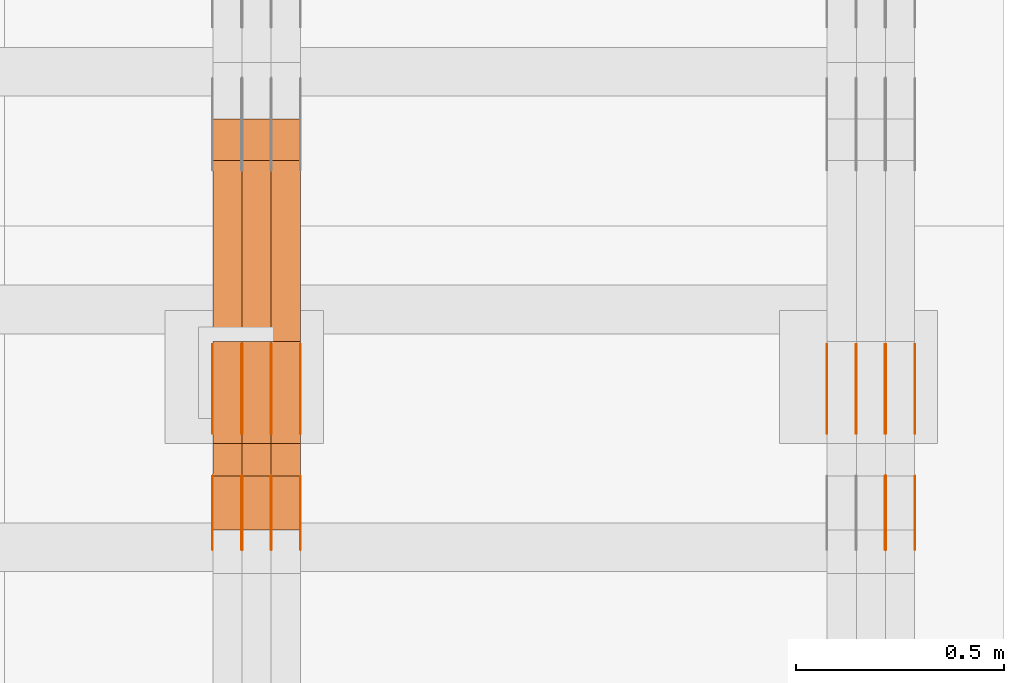
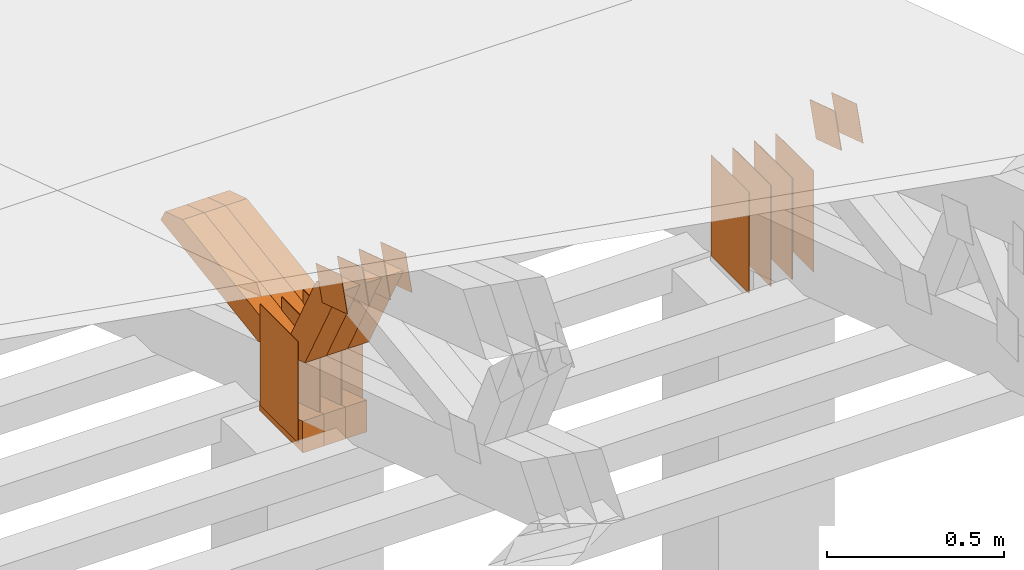
# One storey, part 327 of 385: 30 proxies.
"""IFC2X3 building model written with IfcOpenShell, lengths in millimetres."""

from ifc_helpers import new_model, entity, si_unit, converted_unit, derived_unit, direction, frame, origin, origin_2d_with_axis, place, context, subcontext, project, spatial, polyline, rectangle, outline, extrude, source, transform, mapped, material, type_object, type_shapes, element, save


model = new_model("IFC2X3")

# Units and contexts
model_context = context("Model", 3, precision=0.01, world=origin(), true_north=direction((6.12303176911189e-17, 1.0)))
body_context = subcontext(model_context, "Body", "Model", "MODEL_VIEW")
ifc_project = project(units=[si_unit("LENGTHUNIT", "METRE", prefix="MILLI"), si_unit("AREAUNIT", "SQUARE_METRE"), si_unit("VOLUMEUNIT", "CUBIC_METRE"), converted_unit("PLANEANGLEUNIT", "DEGREE", entity("IfcRatioMeasure", 0.0174532925199433), si_unit("PLANEANGLEUNIT", "RADIAN"), dimensions=[0, 0, 0, 0, 0, 0, 0]), si_unit("MASSUNIT", "GRAM", prefix="KILO"), derived_unit("MASSDENSITYUNIT", [(si_unit("MASSUNIT", "GRAM", prefix="KILO"), 1), (si_unit("LENGTHUNIT", "METRE"), -3)]), si_unit("TIMEUNIT", "SECOND"), si_unit("FREQUENCYUNIT", "HERTZ"), si_unit("THERMODYNAMICTEMPERATUREUNIT", "DEGREE_CELSIUS"), derived_unit("THERMALTRANSMITTANCEUNIT", [(si_unit("MASSUNIT", "GRAM", prefix="KILO"), 1), (si_unit("THERMODYNAMICTEMPERATUREUNIT", "KELVIN"), -1), (si_unit("TIMEUNIT", "SECOND"), -3)]), derived_unit("VOLUMETRICFLOWRATEUNIT", [(si_unit("LENGTHUNIT", "METRE"), 3), (si_unit("TIMEUNIT", "SECOND"), -1)]), si_unit("ELECTRICCURRENTUNIT", "AMPERE"), si_unit("ELECTRICVOLTAGEUNIT", "VOLT"), si_unit("POWERUNIT", "WATT"), si_unit("FORCEUNIT", "NEWTON", prefix="KILO"), si_unit("ILLUMINANCEUNIT", "LUX"), si_unit("LUMINOUSFLUXUNIT", "LUMEN"), si_unit("LUMINOUSINTENSITYUNIT", "CANDELA"), derived_unit("USERDEFINED", [(si_unit("MASSUNIT", "GRAM", prefix="KILO"), -1), (si_unit("LENGTHUNIT", "METRE"), -2), (si_unit("TIMEUNIT", "SECOND"), 3), (si_unit("LUMINOUSFLUXUNIT", "LUMEN"), 1)]), derived_unit("LINEARVELOCITYUNIT", [(si_unit("LENGTHUNIT", "METRE"), 1), (si_unit("TIMEUNIT", "SECOND"), -1)]), si_unit("PRESSUREUNIT", "PASCAL"), derived_unit("USERDEFINED", [(si_unit("LENGTHUNIT", "METRE"), -2), (si_unit("MASSUNIT", "GRAM", prefix="KILO"), 1), (si_unit("TIMEUNIT", "SECOND"), -2)])], contexts=[model_context])

# Site, building, storey
site_placement = place(None, origin())
site = spatial("IfcSite", under=ifc_project, at=site_placement, CompositionType="ELEMENT")
building_placement = place(site_placement, origin())
building = spatial("IfcBuilding", under=site, at=building_placement, CompositionType="ELEMENT")
storey_placement = place(building_placement, origin())
storey = spatial("IfcBuildingStorey", under=building, at=storey_placement, Name="Default", CompositionType="ELEMENT", Elevation=0.0)

# Proxies
ifc_material_1 = material(Name="IfcSurfaceStyle #615826")
building_element_proxy_type_1 = type_object("IfcBuildingElementProxyType", PredefinedType="NOTDEFINED", material=ifc_material_1)
shared_shape_1 = source(origin(), body_context, "Body", "SweptSolid", [
    extrude(rectangle(XDim=350.0, YDim=215.999999999984, at=origin_2d_with_axis()), frame((175.0, 108.0, 0.0), z_axis=(0.0, 0.0, 1.0), x_axis=(-1.0, 0.0, 0.0)), (0.0, 0.0, 1.0), 1.29999999999999),
])
type_shapes(building_element_proxy_type_1, [shared_shape_1])
proxy_1_placement = place(building_placement, frame((49861.3, 17459.2939453125, 3165.36425781251), z_axis=(-1.0, 0.0, 0.0), x_axis=(0.0, 0.0, -1.0)))
element("IfcBuildingElementProxy", 1, at=proxy_1_placement, inside=storey, type_object=building_element_proxy_type_1, material=ifc_material_1, context=body_context, shape_type="MappedRepresentation", body=[
    mapped(shared_shape_1, transform((0.0, 0.0, 0.0), scale=1.0)),
])
ifc_material_2 = material(Name="IfcSurfaceStyle #615769")
building_element_proxy_type_2 = type_object("IfcBuildingElementProxyType", PredefinedType="NOTDEFINED", material=ifc_material_2)
shared_shape_2 = source(origin(), body_context, "Body", "SweptSolid", [
    extrude(rectangle(XDim=350.0, YDim=215.999999999984, at=origin_2d_with_axis()), frame((175.0, 108.0, 0.0), z_axis=(0.0, 0.0, 1.0), x_axis=(-1.0, 0.0, 0.0)), (0.0, 0.0, 1.0), 1.29999999999999),
])
type_shapes(building_element_proxy_type_2, [shared_shape_2])
proxy_2_placement = place(building_placement, frame((49790.0, 17459.2939453125, 3165.36425781251), z_axis=(-1.0, 0.0, 0.0), x_axis=(0.0, 0.0, -1.0)))
element("IfcBuildingElementProxy", 2, at=proxy_2_placement, inside=storey, type_object=building_element_proxy_type_2, material=ifc_material_2, context=body_context, shape_type="MappedRepresentation", body=[
    mapped(shared_shape_2, transform((0.0, 0.0, 0.0), scale=1.0)),
])
ifc_material_3 = material(Name="IfcSurfaceStyle #615712")
building_element_proxy_type_3 = type_object("IfcBuildingElementProxyType", PredefinedType="NOTDEFINED", material=ifc_material_3)
shared_shape_3 = source(origin(), body_context, "Body", "SweptSolid", [
    extrude(rectangle(XDim=350.0, YDim=215.999999999984, at=origin_2d_with_axis()), frame((175.0, 108.0, 0.0), z_axis=(0.0, 0.0, 1.0), x_axis=(-1.0, 0.0, 0.0)), (0.0, 0.0, 1.0), 1.29999999999999),
])
type_shapes(building_element_proxy_type_3, [shared_shape_3])
proxy_3_placement = place(building_placement, frame((49791.3, 17459.2939453125, 3165.36425781251), z_axis=(-1.0, 0.0, 0.0), x_axis=(0.0, 0.0, -1.0)))
element("IfcBuildingElementProxy", 3, at=proxy_3_placement, inside=storey, type_object=building_element_proxy_type_3, material=ifc_material_3, context=body_context, shape_type="MappedRepresentation", body=[
    mapped(shared_shape_3, transform((0.0, 0.0, 0.0), scale=1.0)),
])
ifc_material_4 = material(Name="IfcSurfaceStyle #615655")
building_element_proxy_type_4 = type_object("IfcBuildingElementProxyType", PredefinedType="NOTDEFINED", material=ifc_material_4)
shared_shape_4 = source(origin(), body_context, "Body", "SweptSolid", [
    extrude(rectangle(XDim=350.0, YDim=215.999999999984, at=origin_2d_with_axis()), frame((175.0, 108.0, 0.0), z_axis=(0.0, 0.0, 1.0), x_axis=(-1.0, 0.0, 0.0)), (0.0, 0.0, 1.0), 1.29999999999998),
])
type_shapes(building_element_proxy_type_4, [shared_shape_4])
proxy_4_placement = place(building_placement, frame((49720.0, 17459.2939453125, 3165.36425781251), z_axis=(-1.0, 0.0, 0.0), x_axis=(0.0, 0.0, -1.0)))
element("IfcBuildingElementProxy", 4, at=proxy_4_placement, inside=storey, type_object=building_element_proxy_type_4, material=ifc_material_4, context=body_context, shape_type="MappedRepresentation", body=[
    mapped(shared_shape_4, transform((0.0, 0.0, 0.0), scale=1.0)),
])
ifc_material_5 = material(Name="IfcSurfaceStyle #615598")
building_element_proxy_type_5 = type_object("IfcBuildingElementProxyType", PredefinedType="NOTDEFINED", material=ifc_material_5)
shared_shape_5 = source(origin(), body_context, "Body", "SweptSolid", [
    extrude(rectangle(XDim=350.0, YDim=215.999999999984, at=origin_2d_with_axis()), frame((175.0, 108.0, 0.0), z_axis=(0.0, 0.0, 1.0), x_axis=(-1.0, 0.0, 0.0)), (0.0, 0.0, 1.0), 1.29999999999998),
])
type_shapes(building_element_proxy_type_5, [shared_shape_5])
proxy_5_placement = place(building_placement, frame((49721.3, 17459.2939453125, 3165.36425781251), z_axis=(-1.0, 0.0, 0.0), x_axis=(0.0, 0.0, -1.0)))
element("IfcBuildingElementProxy", 5, at=proxy_5_placement, inside=storey, type_object=building_element_proxy_type_5, material=ifc_material_5, context=body_context, shape_type="MappedRepresentation", body=[
    mapped(shared_shape_5, transform((0.0, 0.0, 0.0), scale=1.0)),
])
ifc_material_6 = material(Name="IfcSurfaceStyle #615541")
building_element_proxy_type_6 = type_object("IfcBuildingElementProxyType", PredefinedType="NOTDEFINED", material=ifc_material_6)
shared_shape_6 = source(origin(), body_context, "Body", "SweptSolid", [
    extrude(rectangle(XDim=350.0, YDim=215.999999999984, at=origin_2d_with_axis()), frame((175.0, 108.0, 0.0), z_axis=(0.0, 0.0, 1.0), x_axis=(-1.0, 0.0, 0.0)), (0.0, 0.0, 1.0), 1.29999999999998),
])
type_shapes(building_element_proxy_type_6, [shared_shape_6])
proxy_6_placement = place(building_placement, frame((49650.0, 17459.2939453125, 3165.36425781251), z_axis=(-1.0, 0.0, 0.0), x_axis=(0.0, 0.0, -1.0)))
element("IfcBuildingElementProxy", 6, at=proxy_6_placement, inside=storey, type_object=building_element_proxy_type_6, material=ifc_material_6, context=body_context, shape_type="MappedRepresentation", body=[
    mapped(shared_shape_6, transform((0.0, 0.0, 0.0), scale=1.0)),
])
ifc_material_7 = material(Name="IfcSurfaceStyle #612406")
building_element_proxy_type_7 = type_object("IfcBuildingElementProxyType", PredefinedType="NOTDEFINED", material=ifc_material_7)
shared_shape_7 = source(origin(), body_context, "Body", "SweptSolid", [
    extrude(outline(polyline([(-74.9998605591058, -59.9999264677524), (74.999875428623, -59.9999264677524), (74.9998605591068, 59.9999264677524), (-74.9998754286239, 59.9999264677524), (-74.9998605591058, -59.9999264677524)])), frame((75.0002460484325, 60.0000016373508, 0.0), z_axis=(0.0, 0.0, 1.0), x_axis=(-1.0, 0.0, 0.0)), (0.0, 0.0, 1.0), 1.3),
])
type_shapes(building_element_proxy_type_7, [shared_shape_7])
proxy_7_placement = place(building_placement, frame((49861.3, 17107.0599369346, 3383.82825001787), z_axis=(-1.0, 0.0, 0.0), x_axis=(0.0, -0.951056516295154, 0.309016994374948)))
element("IfcBuildingElementProxy", 7, at=proxy_7_placement, inside=storey, type_object=building_element_proxy_type_7, material=ifc_material_7, context=body_context, shape_type="MappedRepresentation", body=[
    mapped(shared_shape_7, transform((0.0, 0.0, 0.0), scale=1.0)),
])
ifc_material_8 = material(Name="IfcSurfaceStyle #612349")
building_element_proxy_type_8 = type_object("IfcBuildingElementProxyType", PredefinedType="NOTDEFINED", material=ifc_material_8)
shared_shape_8 = source(origin(), body_context, "Body", "SweptSolid", [
    extrude(outline(polyline([(-74.9998605591058, -59.9999264677524), (74.999875428623, -59.9999264677524), (74.9998605591068, 59.9999264677524), (-74.9998754286239, 59.9999264677524), (-74.9998605591058, -59.9999264677524)])), frame((75.0002460484325, 60.0000016373508, 0.0), z_axis=(0.0, 0.0, 1.0), x_axis=(-1.0, 0.0, 0.0)), (0.0, 0.0, 1.0), 1.3),
])
type_shapes(building_element_proxy_type_8, [shared_shape_8])
proxy_8_placement = place(building_placement, frame((49790.0, 17107.0599369346, 3383.82825001787), z_axis=(-1.0, 0.0, 0.0), x_axis=(0.0, -0.951056516295154, 0.309016994374948)))
element("IfcBuildingElementProxy", 8, at=proxy_8_placement, inside=storey, type_object=building_element_proxy_type_8, material=ifc_material_8, context=body_context, shape_type="MappedRepresentation", body=[
    mapped(shared_shape_8, transform((0.0, 0.0, 0.0), scale=1.0)),
])
ifc_material_9 = material(Name="IfcSurfaceStyle #612292")
building_element_proxy_type_9 = type_object("IfcBuildingElementProxyType", PredefinedType="NOTDEFINED", material=ifc_material_9)
shared_shape_9 = source(origin(), body_context, "Body", "SweptSolid", [
    extrude(outline(polyline([(-74.9998605591058, -59.9999264677524), (74.999875428623, -59.9999264677524), (74.9998605591068, 59.9999264677524), (-74.9998754286239, 59.9999264677524), (-74.9998605591058, -59.9999264677524)])), frame((75.0002460484325, 60.0000016373508, 0.0), z_axis=(0.0, 0.0, 1.0), x_axis=(-1.0, 0.0, 0.0)), (0.0, 0.0, 1.0), 1.3),
])
type_shapes(building_element_proxy_type_9, [shared_shape_9])
proxy_9_placement = place(building_placement, frame((49791.3, 17107.0599369346, 3383.82825001787), z_axis=(-1.0, 0.0, 0.0), x_axis=(0.0, -0.951056516295154, 0.309016994374948)))
element("IfcBuildingElementProxy", 9, at=proxy_9_placement, inside=storey, type_object=building_element_proxy_type_9, material=ifc_material_9, context=body_context, shape_type="MappedRepresentation", body=[
    mapped(shared_shape_9, transform((0.0, 0.0, 0.0), scale=1.0)),
])
ifc_material_10 = material(Name="IfcSurfaceStyle #581394")
building_element_proxy_type_10 = type_object("IfcBuildingElementProxyType", PredefinedType="NOTDEFINED", material=ifc_material_10)
shared_shape_10 = source(origin(), body_context, "Body", "SweptSolid", [
    extrude(rectangle(XDim=350.0, YDim=215.999999999984, at=origin_2d_with_axis()), frame((175.0, 108.0, 0.0), z_axis=(0.0, 0.0, 1.0), x_axis=(-1.0, 0.0, 0.0)), (0.0, 0.0, 1.0), 1.29999999999999),
])
type_shapes(building_element_proxy_type_10, [shared_shape_10])
proxy_10_placement = place(building_placement, frame((48386.3, 17459.2939453125, 3165.36425781251), z_axis=(-1.0, 0.0, 0.0), x_axis=(0.0, 0.0, -1.0)))
element("IfcBuildingElementProxy", 10, at=proxy_10_placement, inside=storey, type_object=building_element_proxy_type_10, material=ifc_material_10, context=body_context, shape_type="MappedRepresentation", body=[
    mapped(shared_shape_10, transform((0.0, 0.0, 0.0), scale=1.0)),
])
ifc_material_11 = material(Name="IfcSurfaceStyle #581337")
building_element_proxy_type_11 = type_object("IfcBuildingElementProxyType", PredefinedType="NOTDEFINED", material=ifc_material_11)
shared_shape_11 = source(origin(), body_context, "Body", "SweptSolid", [
    extrude(rectangle(XDim=350.0, YDim=215.999999999984, at=origin_2d_with_axis()), frame((175.0, 108.0, 0.0), z_axis=(0.0, 0.0, 1.0), x_axis=(-1.0, 0.0, 0.0)), (0.0, 0.0, 1.0), 1.29999999999999),
])
type_shapes(building_element_proxy_type_11, [shared_shape_11])
proxy_11_placement = place(building_placement, frame((48315.0, 17459.2939453125, 3165.36425781251), z_axis=(-1.0, 0.0, 0.0), x_axis=(0.0, 0.0, -1.0)))
element("IfcBuildingElementProxy", 11, at=proxy_11_placement, inside=storey, type_object=building_element_proxy_type_11, material=ifc_material_11, context=body_context, shape_type="MappedRepresentation", body=[
    mapped(shared_shape_11, transform((0.0, 0.0, 0.0), scale=1.0)),
])
ifc_material_12 = material(Name="IfcSurfaceStyle #581280")
building_element_proxy_type_12 = type_object("IfcBuildingElementProxyType", PredefinedType="NOTDEFINED", material=ifc_material_12)
shared_shape_12 = source(origin(), body_context, "Body", "SweptSolid", [
    extrude(rectangle(XDim=350.0, YDim=215.999999999984, at=origin_2d_with_axis()), frame((175.0, 108.0, 0.0), z_axis=(0.0, 0.0, 1.0), x_axis=(-1.0, 0.0, 0.0)), (0.0, 0.0, 1.0), 1.29999999999999),
])
type_shapes(building_element_proxy_type_12, [shared_shape_12])
proxy_12_placement = place(building_placement, frame((48316.3, 17459.2939453125, 3165.36425781251), z_axis=(-1.0, 0.0, 0.0), x_axis=(0.0, 0.0, -1.0)))
element("IfcBuildingElementProxy", 12, at=proxy_12_placement, inside=storey, type_object=building_element_proxy_type_12, material=ifc_material_12, context=body_context, shape_type="MappedRepresentation", body=[
    mapped(shared_shape_12, transform((0.0, 0.0, 0.0), scale=1.0)),
])
ifc_material_13 = material(Name="IfcSurfaceStyle #581223")
building_element_proxy_type_13 = type_object("IfcBuildingElementProxyType", PredefinedType="NOTDEFINED", material=ifc_material_13)
shared_shape_13 = source(origin(), body_context, "Body", "SweptSolid", [
    extrude(rectangle(XDim=350.0, YDim=215.999999999984, at=origin_2d_with_axis()), frame((175.0, 108.0, 0.0), z_axis=(0.0, 0.0, 1.0), x_axis=(-1.0, 0.0, 0.0)), (0.0, 0.0, 1.0), 1.29999999999998),
])
type_shapes(building_element_proxy_type_13, [shared_shape_13])
proxy_13_placement = place(building_placement, frame((48245.0, 17459.2939453125, 3165.36425781251), z_axis=(-1.0, 0.0, 0.0), x_axis=(0.0, 0.0, -1.0)))
element("IfcBuildingElementProxy", 13, at=proxy_13_placement, inside=storey, type_object=building_element_proxy_type_13, material=ifc_material_13, context=body_context, shape_type="MappedRepresentation", body=[
    mapped(shared_shape_13, transform((0.0, 0.0, 0.0), scale=1.0)),
])
ifc_material_14 = material(Name="IfcSurfaceStyle #581166")
building_element_proxy_type_14 = type_object("IfcBuildingElementProxyType", PredefinedType="NOTDEFINED", material=ifc_material_14)
shared_shape_14 = source(origin(), body_context, "Body", "SweptSolid", [
    extrude(rectangle(XDim=350.0, YDim=215.999999999984, at=origin_2d_with_axis()), frame((175.0, 108.0, 0.0), z_axis=(0.0, 0.0, 1.0), x_axis=(-1.0, 0.0, 0.0)), (0.0, 0.0, 1.0), 1.29999999999998),
])
type_shapes(building_element_proxy_type_14, [shared_shape_14])
proxy_14_placement = place(building_placement, frame((48246.3, 17459.2939453125, 3165.36425781251), z_axis=(-1.0, 0.0, 0.0), x_axis=(0.0, 0.0, -1.0)))
element("IfcBuildingElementProxy", 14, at=proxy_14_placement, inside=storey, type_object=building_element_proxy_type_14, material=ifc_material_14, context=body_context, shape_type="MappedRepresentation", body=[
    mapped(shared_shape_14, transform((0.0, 0.0, 0.0), scale=1.0)),
])
ifc_material_15 = material(Name="IfcSurfaceStyle #581109")
building_element_proxy_type_15 = type_object("IfcBuildingElementProxyType", PredefinedType="NOTDEFINED", material=ifc_material_15)
shared_shape_15 = source(origin(), body_context, "Body", "SweptSolid", [
    extrude(rectangle(XDim=350.0, YDim=215.999999999984, at=origin_2d_with_axis()), frame((175.0, 108.0, 0.0), z_axis=(0.0, 0.0, 1.0), x_axis=(-1.0, 0.0, 0.0)), (0.0, 0.0, 1.0), 1.29999999999998),
])
type_shapes(building_element_proxy_type_15, [shared_shape_15])
proxy_15_placement = place(building_placement, frame((48175.0, 17459.2939453125, 3165.36425781251), z_axis=(-1.0, 0.0, 0.0), x_axis=(0.0, 0.0, -1.0)))
element("IfcBuildingElementProxy", 15, at=proxy_15_placement, inside=storey, type_object=building_element_proxy_type_15, material=ifc_material_15, context=body_context, shape_type="MappedRepresentation", body=[
    mapped(shared_shape_15, transform((0.0, 0.0, 0.0), scale=1.0)),
])
ifc_material_16 = material(Name="IfcSurfaceStyle #577974")
building_element_proxy_type_16 = type_object("IfcBuildingElementProxyType", PredefinedType="NOTDEFINED", material=ifc_material_16)
shared_shape_16 = source(origin(), body_context, "Body", "SweptSolid", [
    extrude(outline(polyline([(-74.9998605591058, -59.9999264677524), (74.999875428623, -59.9999264677524), (74.9998605591068, 59.9999264677524), (-74.9998754286239, 59.9999264677524), (-74.9998605591058, -59.9999264677524)])), frame((75.0002460484325, 60.0000016373508, 0.0), z_axis=(0.0, 0.0, 1.0), x_axis=(-1.0, 0.0, 0.0)), (0.0, 0.0, 1.0), 1.3),
])
type_shapes(building_element_proxy_type_16, [shared_shape_16])
proxy_16_placement = place(building_placement, frame((48386.3, 17107.0599369346, 3383.82825001787), z_axis=(-1.0, 0.0, 0.0), x_axis=(0.0, -0.951056516295154, 0.309016994374948)))
element("IfcBuildingElementProxy", 16, at=proxy_16_placement, inside=storey, type_object=building_element_proxy_type_16, material=ifc_material_16, context=body_context, shape_type="MappedRepresentation", body=[
    mapped(shared_shape_16, transform((0.0, 0.0, 0.0), scale=1.0)),
])
ifc_material_17 = material(Name="IfcSurfaceStyle #577917")
building_element_proxy_type_17 = type_object("IfcBuildingElementProxyType", PredefinedType="NOTDEFINED", material=ifc_material_17)
shared_shape_17 = source(origin(), body_context, "Body", "SweptSolid", [
    extrude(outline(polyline([(-74.9998605591058, -59.9999264677524), (74.999875428623, -59.9999264677524), (74.9998605591068, 59.9999264677524), (-74.9998754286239, 59.9999264677524), (-74.9998605591058, -59.9999264677524)])), frame((75.0002460484325, 60.0000016373508, 0.0), z_axis=(0.0, 0.0, 1.0), x_axis=(-1.0, 0.0, 0.0)), (0.0, 0.0, 1.0), 1.3),
])
type_shapes(building_element_proxy_type_17, [shared_shape_17])
proxy_17_placement = place(building_placement, frame((48315.0, 17107.0599369346, 3383.82825001787), z_axis=(-1.0, 0.0, 0.0), x_axis=(0.0, -0.951056516295154, 0.309016994374948)))
element("IfcBuildingElementProxy", 17, at=proxy_17_placement, inside=storey, type_object=building_element_proxy_type_17, material=ifc_material_17, context=body_context, shape_type="MappedRepresentation", body=[
    mapped(shared_shape_17, transform((0.0, 0.0, 0.0), scale=1.0)),
])
ifc_material_18 = material(Name="IfcSurfaceStyle #577860")
building_element_proxy_type_18 = type_object("IfcBuildingElementProxyType", PredefinedType="NOTDEFINED", material=ifc_material_18)
shared_shape_18 = source(origin(), body_context, "Body", "SweptSolid", [
    extrude(outline(polyline([(-74.9998605591058, -59.9999264677524), (74.999875428623, -59.9999264677524), (74.9998605591068, 59.9999264677524), (-74.9998754286239, 59.9999264677524), (-74.9998605591058, -59.9999264677524)])), frame((75.0002460484325, 60.0000016373508, 0.0), z_axis=(0.0, 0.0, 1.0), x_axis=(-1.0, 0.0, 0.0)), (0.0, 0.0, 1.0), 1.3),
])
type_shapes(building_element_proxy_type_18, [shared_shape_18])
proxy_18_placement = place(building_placement, frame((48316.3, 17107.0599369346, 3383.82825001787), z_axis=(-1.0, 0.0, 0.0), x_axis=(0.0, -0.951056516295154, 0.309016994374948)))
element("IfcBuildingElementProxy", 18, at=proxy_18_placement, inside=storey, type_object=building_element_proxy_type_18, material=ifc_material_18, context=body_context, shape_type="MappedRepresentation", body=[
    mapped(shared_shape_18, transform((0.0, 0.0, 0.0), scale=1.0)),
])
ifc_material_19 = material(Name="IfcSurfaceStyle #577803")
building_element_proxy_type_19 = type_object("IfcBuildingElementProxyType", PredefinedType="NOTDEFINED", material=ifc_material_19)
shared_shape_19 = source(origin(), body_context, "Body", "SweptSolid", [
    extrude(outline(polyline([(-74.9998605591058, -59.9999264677524), (74.999875428623, -59.9999264677524), (74.9998605591068, 59.9999264677524), (-74.9998754286239, 59.9999264677524), (-74.9998605591058, -59.9999264677524)])), frame((75.0002460484325, 60.0000016373508, 0.0), z_axis=(0.0, 0.0, 1.0), x_axis=(-1.0, 0.0, 0.0)), (0.0, 0.0, 1.0), 1.29999999999999),
])
type_shapes(building_element_proxy_type_19, [shared_shape_19])
proxy_19_placement = place(building_placement, frame((48245.0, 17107.0599369346, 3383.82825001787), z_axis=(-1.0, 0.0, 0.0), x_axis=(0.0, -0.951056516295154, 0.309016994374948)))
element("IfcBuildingElementProxy", 19, at=proxy_19_placement, inside=storey, type_object=building_element_proxy_type_19, material=ifc_material_19, context=body_context, shape_type="MappedRepresentation", body=[
    mapped(shared_shape_19, transform((0.0, 0.0, 0.0), scale=1.0)),
])
ifc_material_20 = material(Name="IfcSurfaceStyle #577746")
building_element_proxy_type_20 = type_object("IfcBuildingElementProxyType", PredefinedType="NOTDEFINED", material=ifc_material_20)
shared_shape_20 = source(origin(), body_context, "Body", "SweptSolid", [
    extrude(outline(polyline([(-74.9998605591058, -59.9999264677524), (74.999875428623, -59.9999264677524), (74.9998605591068, 59.9999264677524), (-74.9998754286239, 59.9999264677524), (-74.9998605591058, -59.9999264677524)])), frame((75.0002460484325, 60.0000016373508, 0.0), z_axis=(0.0, 0.0, 1.0), x_axis=(-1.0, 0.0, 0.0)), (0.0, 0.0, 1.0), 1.29999999999999),
])
type_shapes(building_element_proxy_type_20, [shared_shape_20])
proxy_20_placement = place(building_placement, frame((48246.3, 17107.0599369346, 3383.82825001787), z_axis=(-1.0, 0.0, 0.0), x_axis=(0.0, -0.951056516295154, 0.309016994374948)))
element("IfcBuildingElementProxy", 20, at=proxy_20_placement, inside=storey, type_object=building_element_proxy_type_20, material=ifc_material_20, context=body_context, shape_type="MappedRepresentation", body=[
    mapped(shared_shape_20, transform((0.0, 0.0, 0.0), scale=1.0)),
])
ifc_material_21 = material(Name="IfcSurfaceStyle #577689")
building_element_proxy_type_21 = type_object("IfcBuildingElementProxyType", PredefinedType="NOTDEFINED", material=ifc_material_21)
shared_shape_21 = source(origin(), body_context, "Body", "SweptSolid", [
    extrude(outline(polyline([(-74.9998605591058, -59.9999264677524), (74.999875428623, -59.9999264677524), (74.9998605591068, 59.9999264677524), (-74.9998754286239, 59.9999264677524), (-74.9998605591058, -59.9999264677524)])), frame((75.0002460484325, 60.0000016373508, 0.0), z_axis=(0.0, 0.0, 1.0), x_axis=(-1.0, 0.0, 0.0)), (0.0, 0.0, 1.0), 1.29999999999999),
])
type_shapes(building_element_proxy_type_21, [shared_shape_21])
proxy_21_placement = place(building_placement, frame((48175.0, 17107.0599369346, 3383.82825001787), z_axis=(-1.0, 0.0, 0.0), x_axis=(0.0, -0.951056516295154, 0.309016994374948)))
element("IfcBuildingElementProxy", 21, at=proxy_21_placement, inside=storey, type_object=building_element_proxy_type_21, material=ifc_material_21, context=body_context, shape_type="MappedRepresentation", body=[
    mapped(shared_shape_21, transform((0.0, 0.0, 0.0), scale=1.0)),
])
ifc_material_22 = material(Name="IfcSurfaceStyle #569685")
building_element_proxy_type_22 = type_object("IfcBuildingElementProxyType", Name="T1-E1 569683", PredefinedType="NOTDEFINED", material=ifc_material_22)
shared_shape_22 = source(origin(), body_context, "Body", "SweptSolid", [
    extrude(outline(polyline([(4.4675903320374, -122.500000000001), (35.3350219726624, -122.500000000001), (35.3350219726501, 122.500000000001), (-75.1376342773499, 122.500000000001), (4.4675903320374, -122.500000000001)])), frame((35.3350219726624, 122.50000005215, 0.0), z_axis=(0.0, 0.0, 1.0), x_axis=(-1.0, 0.0, 0.0)), (0.0, 0.0, 1.0), 70.0),
])
type_shapes(building_element_proxy_type_22, [shared_shape_22])
proxy_22_placement = place(building_placement, frame((48385.0, 17220.0, 2794.30932617186), z_axis=(-1.0, 0.0, 0.0), x_axis=(0.0, 0.0, 1.0)))
element("IfcBuildingElementProxy", 22, at=proxy_22_placement, inside=storey, type_object=building_element_proxy_type_22, material=ifc_material_22, Name="T1-E1", context=body_context, shape_type="MappedRepresentation", body=[
    mapped(shared_shape_22, transform((0.0, 0.0, 0.0), scale=1.0)),
])
ifc_material_23 = material(Name="IfcSurfaceStyle #569628")
building_element_proxy_type_23 = type_object("IfcBuildingElementProxyType", Name="T1-E1 569626", PredefinedType="NOTDEFINED", material=ifc_material_23)
shared_shape_23 = source(origin(), body_context, "Body", "SweptSolid", [
    extrude(outline(polyline([(4.4675903320374, -122.500000000001), (35.3350219726624, -122.500000000001), (35.3350219726501, 122.500000000001), (-75.1376342773499, 122.500000000001), (4.4675903320374, -122.500000000001)])), frame((35.3350219726624, 122.50000005215, 0.0), z_axis=(0.0, 0.0, 1.0), x_axis=(-1.0, 0.0, 0.0)), (0.0, 0.0, 1.0), 70.0),
])
type_shapes(building_element_proxy_type_23, [shared_shape_23])
proxy_23_placement = place(building_placement, frame((48315.0, 17220.0, 2794.30932617186), z_axis=(-1.0, 0.0, 0.0), x_axis=(0.0, 0.0, 1.0)))
element("IfcBuildingElementProxy", 23, at=proxy_23_placement, inside=storey, type_object=building_element_proxy_type_23, material=ifc_material_23, Name="T1-E1", context=body_context, shape_type="MappedRepresentation", body=[
    mapped(shared_shape_23, transform((0.0, 0.0, 0.0), scale=1.0)),
])
ifc_material_24 = material(Name="IfcSurfaceStyle #569571")
building_element_proxy_type_24 = type_object("IfcBuildingElementProxyType", Name="T1-E1 569569", PredefinedType="NOTDEFINED", material=ifc_material_24)
shared_shape_24 = source(origin(), body_context, "Body", "SweptSolid", [
    extrude(outline(polyline([(4.4675903320374, -122.500000000001), (35.3350219726624, -122.500000000001), (35.3350219726501, 122.500000000001), (-75.1376342773499, 122.500000000001), (4.4675903320374, -122.500000000001)])), frame((35.3350219726624, 122.50000005215, 0.0), z_axis=(0.0, 0.0, 1.0), x_axis=(-1.0, 0.0, 0.0)), (0.0, 0.0, 1.0), 70.0),
])
type_shapes(building_element_proxy_type_24, [shared_shape_24])
proxy_24_placement = place(building_placement, frame((48245.0, 17220.0, 2794.30932617186), z_axis=(-1.0, 0.0, 0.0), x_axis=(0.0, 0.0, 1.0)))
element("IfcBuildingElementProxy", 24, at=proxy_24_placement, inside=storey, type_object=building_element_proxy_type_24, material=ifc_material_24, Name="T1-E1", context=body_context, shape_type="MappedRepresentation", body=[
    mapped(shared_shape_24, transform((0.0, 0.0, 0.0), scale=1.0)),
])
ifc_material_25 = material(Name="IfcSurfaceStyle #567930")
building_element_proxy_type_25 = type_object("IfcBuildingElementProxyType", Name="T1-W39 567928", PredefinedType="NOTDEFINED", material=ifc_material_25)
shared_shape_25 = source(origin(), body_context, "Body", "SweptSolid", [
    extrude(outline(polyline([(-191.519946663886, -47.499928106579), (188.32936223763, -47.499928106579), (171.597440144109, 0.000249483340993841), (122.102882529753, 47.4998033649085), (-290.509738247605, 47.4998033649085), (-191.519946663886, -47.499928106579)])), frame((188.329593252001, 47.499957247623, 0.0), z_axis=(0.0, 0.0, 1.0), x_axis=(-1.0, 0.0, 0.0)), (0.0, 0.0, 1.0), 70.0),
])
type_shapes(building_element_proxy_type_25, [shared_shape_25])
proxy_25_placement = place(building_placement, frame((48385.0, 17238.5876916597, 3055.56121424762), z_axis=(-1.0, 0.0, 0.0), x_axis=(0.0, -0.472216932390777, 0.881482370080902)))
element("IfcBuildingElementProxy", 25, at=proxy_25_placement, inside=storey, type_object=building_element_proxy_type_25, material=ifc_material_25, Name="T1-W39", context=body_context, shape_type="MappedRepresentation", body=[
    mapped(shared_shape_25, transform((0.0, 0.0, 0.0), scale=1.0)),
])
ifc_material_26 = material(Name="IfcSurfaceStyle #567864")
building_element_proxy_type_26 = type_object("IfcBuildingElementProxyType", Name="T1-W39 567862", PredefinedType="NOTDEFINED", material=ifc_material_26)
shared_shape_26 = source(origin(), body_context, "Body", "SweptSolid", [
    extrude(outline(polyline([(-191.519946663886, -47.499928106579), (188.32936223763, -47.499928106579), (171.597440144109, 0.000249483340993841), (122.102882529753, 47.4998033649085), (-290.509738247605, 47.4998033649085), (-191.519946663886, -47.499928106579)])), frame((188.329593252001, 47.499957247623, 0.0), z_axis=(0.0, 0.0, 1.0), x_axis=(-1.0, 0.0, 0.0)), (0.0, 0.0, 1.0), 70.0),
])
type_shapes(building_element_proxy_type_26, [shared_shape_26])
proxy_26_placement = place(building_placement, frame((48315.0, 17238.5876916597, 3055.56121424762), z_axis=(-1.0, 0.0, 0.0), x_axis=(0.0, -0.472216932390777, 0.881482370080902)))
element("IfcBuildingElementProxy", 26, at=proxy_26_placement, inside=storey, type_object=building_element_proxy_type_26, material=ifc_material_26, Name="T1-W39", context=body_context, shape_type="MappedRepresentation", body=[
    mapped(shared_shape_26, transform((0.0, 0.0, 0.0), scale=1.0)),
])
ifc_material_27 = material(Name="IfcSurfaceStyle #567798")
building_element_proxy_type_27 = type_object("IfcBuildingElementProxyType", Name="T1-W39 567796", PredefinedType="NOTDEFINED", material=ifc_material_27)
shared_shape_27 = source(origin(), body_context, "Body", "SweptSolid", [
    extrude(outline(polyline([(-191.519946663886, -47.499928106579), (188.32936223763, -47.499928106579), (171.597440144109, 0.000249483340993841), (122.102882529753, 47.4998033649085), (-290.509738247605, 47.4998033649085), (-191.519946663886, -47.499928106579)])), frame((188.329593252001, 47.499957247623, 0.0), z_axis=(0.0, 0.0, 1.0), x_axis=(-1.0, 0.0, 0.0)), (0.0, 0.0, 1.0), 70.0),
])
type_shapes(building_element_proxy_type_27, [shared_shape_27])
proxy_27_placement = place(building_placement, frame((48245.0, 17238.5876916597, 3055.56121424762), z_axis=(-1.0, 0.0, 0.0), x_axis=(0.0, -0.472216932390777, 0.881482370080902)))
element("IfcBuildingElementProxy", 27, at=proxy_27_placement, inside=storey, type_object=building_element_proxy_type_27, material=ifc_material_27, Name="T1-W39", context=body_context, shape_type="MappedRepresentation", body=[
    mapped(shared_shape_27, transform((0.0, 0.0, 0.0), scale=1.0)),
])
ifc_material_28 = material(Name="IfcSurfaceStyle #567534")
building_element_proxy_type_28 = type_object("IfcBuildingElementProxyType", Name="T1-W10 567532", PredefinedType="NOTDEFINED", material=ifc_material_28)
shared_shape_28 = source(origin(), body_context, "Body", "SweptSolid", [
    extrude(outline(polyline([(-459.546036710757, -47.5000436364511), (174.689450869018, -47.5000436364511), (268.831081103959, 0.00011114562912502), (287.286350706789, 47.4999880636365), (-271.260845969009, 47.4999880636366), (-459.546036710757, -47.5000436364511)])), frame((287.286768781132, 47.5001637448091, 0.0), z_axis=(0.0, 0.0, 1.0), x_axis=(-1.0, 0.0, 0.0)), (0.0, 0.0, 1.0), 70.0),
])
type_shapes(building_element_proxy_type_28, [shared_shape_28])
proxy_28_placement = place(building_placement, frame((48385.0, 18025.1410649788, 3112.76453857986), z_axis=(-1.0, 0.0, 0.0), x_axis=(0.0, -0.988299196256916, -0.152527698068035)))
element("IfcBuildingElementProxy", 28, at=proxy_28_placement, inside=storey, type_object=building_element_proxy_type_28, material=ifc_material_28, Name="T1-W10", context=body_context, shape_type="MappedRepresentation", body=[
    mapped(shared_shape_28, transform((0.0, 0.0, 0.0), scale=1.0)),
])
ifc_material_29 = material(Name="IfcSurfaceStyle #567468")
building_element_proxy_type_29 = type_object("IfcBuildingElementProxyType", Name="T1-W10 567466", PredefinedType="NOTDEFINED", material=ifc_material_29)
shared_shape_29 = source(origin(), body_context, "Body", "SweptSolid", [
    extrude(outline(polyline([(-459.546036710757, -47.5000436364511), (174.689450869018, -47.5000436364511), (268.831081103959, 0.00011114562912502), (287.286350706789, 47.4999880636365), (-271.260845969009, 47.4999880636366), (-459.546036710757, -47.5000436364511)])), frame((287.286768781132, 47.5001637448091, 0.0), z_axis=(0.0, 0.0, 1.0), x_axis=(-1.0, 0.0, 0.0)), (0.0, 0.0, 1.0), 70.0),
])
type_shapes(building_element_proxy_type_29, [shared_shape_29])
proxy_29_placement = place(building_placement, frame((48315.0, 18025.1410649788, 3112.76453857986), z_axis=(-1.0, 0.0, 0.0), x_axis=(0.0, -0.988299196256916, -0.152527698068035)))
element("IfcBuildingElementProxy", 29, at=proxy_29_placement, inside=storey, type_object=building_element_proxy_type_29, material=ifc_material_29, Name="T1-W10", context=body_context, shape_type="MappedRepresentation", body=[
    mapped(shared_shape_29, transform((0.0, 0.0, 0.0), scale=1.0)),
])
ifc_material_30 = material(Name="IfcSurfaceStyle #567402")
building_element_proxy_type_30 = type_object("IfcBuildingElementProxyType", Name="T1-W10 567400", PredefinedType="NOTDEFINED", material=ifc_material_30)
shared_shape_30 = source(origin(), body_context, "Body", "SweptSolid", [
    extrude(outline(polyline([(-459.546036710757, -47.5000436364511), (174.689450869018, -47.5000436364511), (268.831081103959, 0.00011114562912502), (287.286350706789, 47.4999880636365), (-271.260845969009, 47.4999880636366), (-459.546036710757, -47.5000436364511)])), frame((287.286768781132, 47.5001637448091, 0.0), z_axis=(0.0, 0.0, 1.0), x_axis=(-1.0, 0.0, 0.0)), (0.0, 0.0, 1.0), 70.0),
])
type_shapes(building_element_proxy_type_30, [shared_shape_30])
proxy_30_placement = place(building_placement, frame((48245.0, 18025.1410649788, 3112.76453857986), z_axis=(-1.0, 0.0, 0.0), x_axis=(0.0, -0.988299196256916, -0.152527698068035)))
element("IfcBuildingElementProxy", 30, at=proxy_30_placement, inside=storey, type_object=building_element_proxy_type_30, material=ifc_material_30, Name="T1-W10", context=body_context, shape_type="MappedRepresentation", body=[
    mapped(shared_shape_30, transform((0.0, 0.0, 0.0), scale=1.0)),
])

save(model, "model.ifc")
